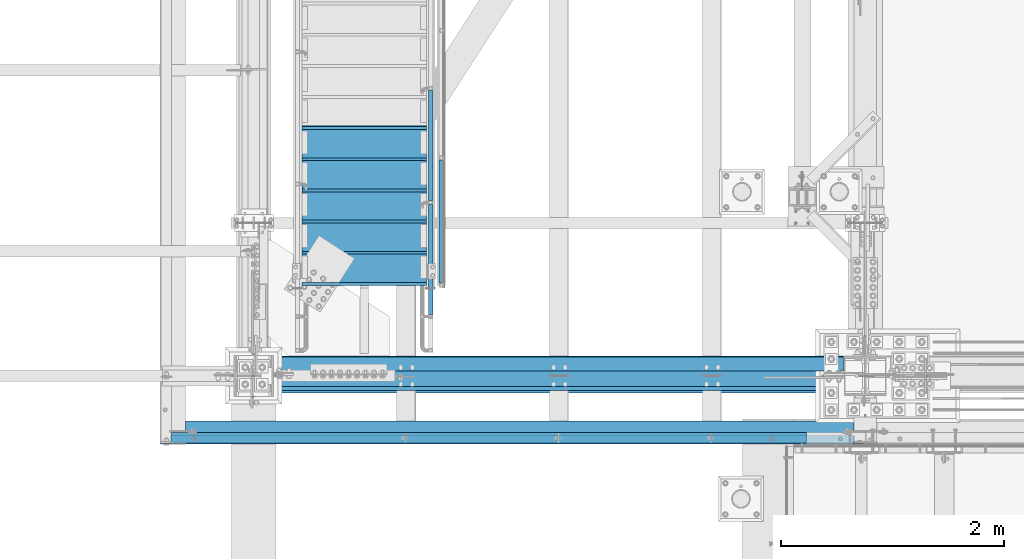
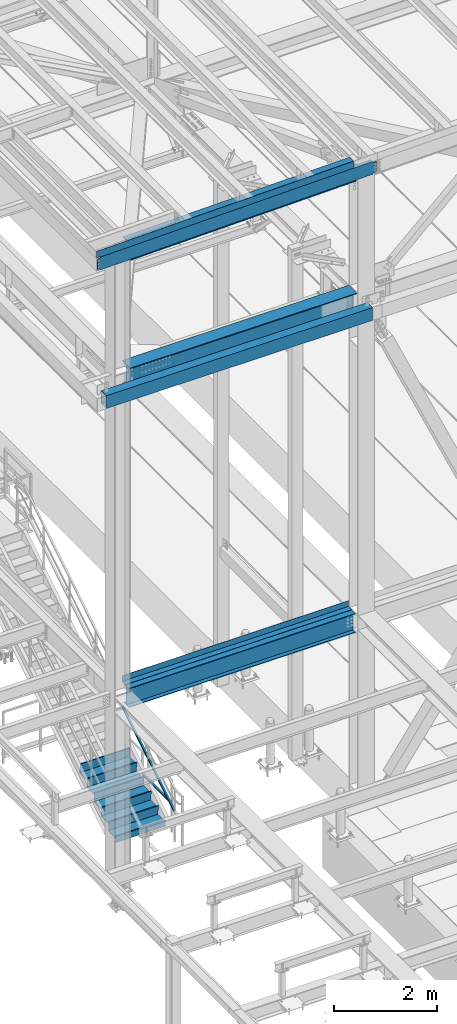
# One storey, part 1744 of 3843: 14 beams, 2 members, 8 elements without a shape of their own.
"""IFC2X3 building model written with IfcOpenShell, lengths in millimetres."""

from ifc_helpers import new_model, si_unit, frame, origin_with_axes, place, context, subcontext, project, spatial, faceted_brep, material, type_object, element, aggregate, save


model = new_model("IFC2X3")

# Units and contexts
model_context = context("Model", 3, precision=1e-05, world=origin_with_axes())
body_context = subcontext(model_context, "Body", "Model", "MODEL_VIEW")
ifc_project = project(units=[si_unit("LENGTHUNIT", "METRE", prefix="MILLI"), si_unit("AREAUNIT", "SQUARE_METRE"), si_unit("VOLUMEUNIT", "CUBIC_METRE"), si_unit("MASSUNIT", "GRAM", prefix="KILO"), si_unit("TIMEUNIT", "SECOND"), si_unit("PLANEANGLEUNIT", "RADIAN"), si_unit("SOLIDANGLEUNIT", "STERADIAN"), si_unit("THERMODYNAMICTEMPERATUREUNIT", "DEGREE_CELSIUS"), si_unit("LUMINOUSINTENSITYUNIT", "LUMEN")], contexts=[model_context])

# Site, building, storey
site_placement = place(None, origin_with_axes())
site = spatial("IfcSite", under=ifc_project, at=site_placement, CompositionType="ELEMENT")
building_placement = place(site_placement, origin_with_axes())
building = spatial("IfcBuilding", under=site, at=building_placement, Name="Undefined", CompositionType="ELEMENT")
storey_placement = place(building_placement, origin_with_axes())
storey = spatial("IfcBuildingStorey", under=building, at=storey_placement, Name="Undefined", CompositionType="ELEMENT", Elevation=0.0)

# Assembly, beam
assembly_1_placement = place(storey_placement, origin_with_axes())
assembly_1 = element("IfcElementAssembly", 1, at=assembly_1_placement, inside=storey, Name="RAIL", AssemblyPlace="NOTDEFINED", PredefinedType="RIGID_FRAME")
ifc_material_1 = material()
beam_type_1 = type_object("IfcBeamType", Name="HSS1-1/2X1-1/2X1/4", PredefinedType="NOTDEFINED")
beam_1_placement = place(assembly_1_placement, frame((38258.75, 26428.6999999811, 31013.4), z_axis=(0.0, 0.0, 1.0), x_axis=(0.0, 1.0, 0.0)))
beam_1 = element("IfcBeam", 2, at=beam_1_placement, type_object=beam_type_1, material=ifc_material_1, Name="RAIL", ObjectType="HSS1-1/2X1-1/2X1/4", context=body_context, shape_type="Brep", body=[
    faceted_brep([(1123.95, -19.0500000000029, 19.0499992350015), (1123.95, -19.0499992350015, -19.0499992350015), (1123.95, 19.0499992350015, -19.0499992350015), (1123.95, 19.0499992350015, 19.0499992350015), (1123.95, -12.6999993299978, 12.6999993300014), (1123.95, 12.6999993299978, 12.6999993300014), (1123.95, 12.6999993299978, -12.6999993300014), (1123.95, -12.6999993299978, -12.6999993300014), (19.0499992350015, 19.0499992350015, -19.0499992350015), (19.0499992350015, 19.0499992350015, 19.0499992350015), (19.0499992350015, -19.0499992350015, 19.0499992350015), (19.0499992350015, -19.0499992350015, -19.0499992350015), (19.0499992350015, 12.6999993299978, 12.6999993299978), (19.0499992350015, -12.6999993299978, 12.6999993299978), (19.0499992350015, -12.6999993299978, -12.6999993299978), (19.0499992350015, 12.6999993299978, -12.6999993299978)], [[[0, 1, 2, 3], [4, 5, 6, 7]], [[8, 9, 3, 2]], [[9, 10, 0, 3]], [[10, 11, 1, 0]], [[11, 8, 2, 1]], [[11, 10, 9, 8], [12, 13, 14, 15]], [[14, 13, 4, 7]], [[15, 14, 7, 6]], [[12, 15, 6, 5]], [[13, 12, 5, 4]]]),
])
aggregate(assembly_1, [beam_1])

# Assembly, members
assembly_2_placement = place(storey_placement, origin_with_axes())
assembly_2 = element("IfcElementAssembly", 3, at=assembly_2_placement, inside=storey, Name="RAIL", AssemblyPlace="NOTDEFINED", PredefinedType="RIGID_FRAME")
member_type = type_object("IfcMemberType", Name="HSS1-1/2X1-1/2X1/4", PredefinedType="NOTDEFINED")
member_1_placement = place(assembly_2_placement, frame((38163.4999999504, 27171.65, 31650.7090912731), z_axis=(0.0, -0.529007926750979, 0.848616882600523), x_axis=(0.0, 0.848616882600524, 0.529007926750978)))
member_1 = element("IfcMember", 4, at=member_1_placement, type_object=member_type, material=ifc_material_1, Name="RAIL", ObjectType="HSS1-1/2X1-1/2X1/4", context=body_context, shape_type="Brep", body=[
    faceted_brep([(1194.15206246817, -19.0499999811145, 19.0499992336445), (1170.40141407416, -19.0499992350015, -19.0499992362566), (1170.40141407416, 19.0499992350015, -19.0499992362566), (1194.15206246817, 19.0499992350015, 19.0499992336445), (1190.19362096973, -12.6999993299978, 12.6999993286627), (1190.19362096973, 12.6999993299978, 12.6999993286627), (1174.35985557328, 12.6999993299978, -12.6999993312675), (1174.35985557328, -12.6999993299978, -12.6999993312675), (10.5729683018217, 19.0499992350015, -19.0499992349742), (34.3236166958304, 19.0499992350015, 19.0499992349305), (34.3236166958304, -19.0500000222455, 19.0499992349305), (10.5729683018217, -19.0499992350015, -19.0499992349742), (30.3651751973375, -12.6999993299978, 12.6999993299451), (14.5314098008821, -12.6999993299978, -12.6999993299924), (14.5314098008821, 12.6999993299978, -12.6999993299924), (30.3651751973375, 12.6999993299978, 12.6999993299451)], [[[0, 1, 2, 3], [4, 5, 6, 7]], [[8, 9, 3, 2]], [[9, 10, 0, 3]], [[10, 11, 1, 0]], [[11, 8, 2, 1]], [[10, 9, 8, 11], [12, 13, 14, 15]], [[13, 12, 4, 7]], [[14, 13, 7, 6]], [[15, 14, 6, 5]], [[12, 15, 5, 4]]]),
])
member_2_placement = place(assembly_2_placement, frame((38163.4999999557, 26149.3, 31013.4000000026), z_axis=(0.0, -0.529007926750979, 0.848616882600523), x_axis=(0.0, 0.848616882600524, 0.529007926750978)))
member_2 = element("IfcMember", 5, at=member_2_placement, type_object=member_type, material=ifc_material_1, Name="RAIL", ObjectType="HSS1-1/2X1-1/2X1/4", context=body_context, shape_type="Brep", body=[
    faceted_brep([(1194.15206246817, -19.0499999811145, 19.0499992336445), (1170.40141407416, -19.0499992350015, -19.0499992362566), (1170.40141407416, 19.0499992350015, -19.0499992362566), (1194.15206246817, 19.0499992350015, 19.0499992336445), (1190.19362096973, -12.6999993299978, 12.6999993286627), (1190.19362096973, 12.6999993299978, 12.6999993286627), (1174.35985557328, 12.6999993299978, -12.6999993312675), (1174.35985557328, -12.6999993299978, -12.6999993312675), (10.5729683018217, 19.0499992350015, -19.0499992349742), (34.3236166958304, 19.0499992350015, 19.0499992349305), (34.3236166958304, -19.0500000222455, 19.0499992349305), (10.5729683018217, -19.0499992350015, -19.0499992349742), (30.3651751973375, -12.6999993299978, 12.6999993299451), (14.5314098008821, -12.6999993299978, -12.6999993299924), (14.5314098008821, 12.6999993299978, -12.6999993299924), (30.3651751973375, 12.6999993299978, 12.6999993299451)], [[[0, 1, 2, 3], [4, 5, 6, 7]], [[8, 9, 3, 2]], [[9, 10, 0, 3]], [[10, 11, 1, 0]], [[11, 8, 2, 1]], [[10, 9, 8, 11], [12, 13, 14, 15]], [[13, 12, 4, 7]], [[14, 13, 7, 6]], [[15, 14, 6, 5]], [[12, 15, 5, 4]]]),
])
aggregate(assembly_2, [member_1, member_2])

# Assembly, beams
assembly_3_placement = place(storey_placement, origin_with_axes())
assembly_3 = element("IfcElementAssembly", 6, at=assembly_3_placement, inside=storey, Name="BEAM", AssemblyPlace="NOTDEFINED", PredefinedType="RIGID_FRAME")
ifc_material_2 = material(Name="STEEL/A572-50")
beam_type_2 = type_object("IfcBeamType", Name="C12X20.7", PredefinedType="NOTDEFINED")
beam_2_placement = place(assembly_3_placement, frame((35741.0235796553, 25044.4000000811, 45559.4950698048), z_axis=(0.0211520550054438, 0.0, -0.999776270257025), x_axis=(0.999776270257024, 0.0, 0.0211520550054619)))
beam_2 = element("IfcBeam", 7, at=beam_2_placement, type_object=beam_type_2, material=ifc_material_2, Name="BEAM", ObjectType="C12X20.7", context=body_context, shape_type="Brep", body=[
    faceted_brep([(20.6374999136679, 30.1625000000058, -126.999999999352), (20.6374999136679, 38.1000000000058, -126.999999999352), (77.7875001037028, 38.1000000000058, -126.999999999302), (77.7875001037028, 30.1625000000058, -126.999999999302), (82.6475796217346, 38.1000000000058, -127.966729921885), (82.6475796217346, 30.1625000000058, -127.966729921885), (86.7677560898665, 38.1000000000058, -130.719743822337), (86.7677560898665, 30.1625000000058, -130.719743822337), (89.5207699903331, 38.1000000000058, -134.839920290469), (89.5207699903403, 30.1625000000058, -134.674927499684), (90.4874999129242, 1.14757858682424e-06, -139.699999808494), (90.4874999129242, 38.1000000000058, -139.699999808494), (90.4874999129315, 38.1000000000058, -152.399999999659), (90.4874999129388, -38.1000000000058, -152.39999980729), (90.4874999129315, -38.1000000000058, -146.047459999667), (6221.00785836641, -38.1000000000058, 146.047460006012), (6221.0078583664, -38.1000000000058, 152.400000005997), (90.4874999126405, -38.1000000000058, 152.39999980975), (90.4874999126478, -38.1000000000058, 146.047459999863), (6221.0078583664, 38.1000000000058, 152.400000005997), (90.4874999126478, 38.1000000000058, 152.399999999849), (77.7875001034699, 30.1625000000058, 126.999999999338), (77.7875001034699, 38.1000000000058, 126.999999999338), (20.6374999136751, 38.1000000000058, 126.999999999272), (20.6374999136751, 30.1625000000058, 126.999999999272), (82.6475796214872, 30.1625000000058, 127.966729921922), (82.6475796214872, 38.1000000000058, 127.966729921922), (86.7677560896191, 30.1625000000058, 130.719743822396), (86.7677560896191, 38.1000000000058, 130.719743822396), (89.5207699900784, 30.1625000000058, 134.674927499873), (89.5207699900784, 38.1000000000058, 134.839920290535), (90.487499912655, 1.14834983833134e-06, 139.699999808552), (90.487499912655, 38.1000000000058, 139.699999808552), (6221.974588289, 30.1625000000058, 134.674927506036), (6221.00785836641, 8.03440343588591e-07, 139.699999872166), (6221.00785836641, 38.1000000000058, 139.699999872166), (6221.974588289, 38.1000000000058, 134.839920354148), (6224.72760218947, 30.1625000000058, 130.719743886017), (6224.72760218947, 38.1000000000058, 130.719743886017), (6228.8477786576, 30.1625000000058, 127.966729985557), (6228.8477786576, 38.1000000000058, 127.966729985557), (6233.70785817563, 30.1625000000058, 127.000000062973), (6233.70785817563, 38.1000000000058, 127.000000062973), (6303.55742588337, 30.1625000000058, 127.000000063053), (6303.55737560392, 38.1000000000058, 127.000000063039), (6303.55742572207, 30.1624999999985, 116.300000027353), (6303.55742595262, 30.1624999999985, -114.299999971117), (6303.55742562941, 30.1625000000058, -126.999999935717), (6303.55737534998, 38.1000000000058, -126.999999935724), (6233.70785817589, 30.1625000000058, -126.999999935797), (6233.70785817589, 38.1000000000058, -126.999999935797), (6228.84777865787, 30.1625000000058, -127.966729858381), (6228.84777865787, 38.1000000000058, -127.966729858381), (6224.72760218974, 30.1625000000058, -130.719743758855), (6224.72760218974, 38.1000000000058, -130.719743758855), (6221.97458828928, 30.1625000000058, -134.674927493536), (6221.97458828928, 38.1000000000058, -134.839920226987), (6221.0078583667, 1.4916731743142e-06, -139.699999745018), (6221.0078583667, 38.1000000000058, -139.699999745018), (6221.00785836671, -38.1000000000058, -146.047459993511), (6221.00785836672, -38.1000000000058, -152.399999993504), (6221.00785836672, 38.1000000000058, -152.399999993504), (20.6374999295222, 30.1625000000004, -114.29999996836), (20.6375001600682, 30.1625000000004, 116.300000028175)], [[[0, 1, 2, 3]], [[3, 2, 4, 5]], [[5, 4, 6, 7]], [[7, 6, 8, 9]], [[10, 11, 12, 13, 14]], [[9, 8, 11, 10]], [[15, 16, 17, 18]], [[16, 19, 20, 17]], [[21, 22, 23, 24]], [[25, 26, 22, 21]], [[27, 28, 26, 25]], [[29, 30, 28, 27]], [[31, 32, 30, 29]], [[17, 20, 32, 31, 18]], [[29, 33, 34, 15, 18, 31]], [[16, 15, 34, 35, 19]], [[33, 36, 35, 34]], [[37, 38, 36, 33]], [[39, 40, 38, 37]], [[41, 42, 40, 39]], [[43, 44, 42, 41]], [[44, 43, 45, 46, 47, 48]], [[47, 49, 50, 48]], [[51, 52, 50, 49]], [[53, 54, 52, 51]], [[55, 56, 54, 53]], [[57, 58, 56, 55]], [[59, 60, 61, 58, 57]], [[60, 59, 14, 13]], [[61, 60, 13, 12]], [[6, 4, 2, 1, 23, 22, 26, 28, 30, 32, 20, 19, 35, 36, 38, 40, 42, 44, 48, 50, 52, 54, 56, 58, 61, 12, 11, 8]], [[62, 63, 24, 23, 1, 0]], [[55, 53, 51, 49, 47, 46, 45, 43, 41, 39, 37, 33, 29, 27, 25, 21, 24, 63, 62, 0, 3, 5, 7, 9]], [[59, 57, 55, 9, 10, 14]]]),
])
ifc_material_3 = material(Name="STEEL/A36")
beam_type_3 = type_object("IfcBeamType", PredefinedType="NOTDEFINED")
beam_3_placement = place(assembly_3_placement, frame((38639.0335905506, 25107.8999997032, 45776.4175910696), z_axis=(0.999776270257024, 0.0, 0.0211520550054619), x_axis=(0.0, -1.0, 0.0)))
beam_3 = element("IfcBeam", 8, at=beam_3_placement, type_object=beam_type_3, material=ifc_material_3, Name="BENT_PLATE", context=body_context, shape_type="Brep", body=[
    faceted_brep([(101.599999703314, -3.17499999719439, -2800.35000762786), (95.2499990730139, -3.1749999972817, -2800.35000762787), (1.01863406598568e-10, -3.17499999720167, -2800.35000762786), (1.0550138540566e-10, 3.17500000279688, -2800.35000762787), (101.599999047881, 3.17500000270957, -2800.35000762787), (101.599999073012, -3.1749999970998, -2895.59999999531), (95.2499990734032, -3.17499999718711, -2895.5999999953), (95.2499997009763, -161.925000941941, 2895.59999999518), (95.2499997016348, -161.92500093647, -2895.59999999545), (101.599999701637, -161.925000911338, -2895.59999999544), (101.599999700979, -161.925000916817, 2895.59999999518), (101.599999047587, 3.17499999699066, 2895.59999999533), (-2.11002770811319e-10, 3.17499999707798, 2895.59999999533), (-2.18278728425503e-10, -3.17500000290602, 2895.59999999533), (95.2499990727156, -3.17500000299333, 2895.59999999533)], [[[0, 1, 2, 3, 4]], [[5, 6, 1, 0]], [[7, 8, 9, 10]], [[11, 12, 13, 14, 7, 10]], [[12, 11, 4, 3]], [[13, 12, 3, 2]], [[14, 13, 2, 1]], [[8, 7, 14, 1, 6]], [[9, 8, 6, 5]], [[11, 10, 9, 5, 0, 4]]]),
])
aggregate(assembly_3, [beam_2, beam_3])

# Assembly, beam
assembly_4_placement = place(storey_placement, origin_with_axes())
assembly_4 = element("IfcElementAssembly", 9, at=assembly_4_placement, inside=storey, Name="BEAM", AssemblyPlace="NOTDEFINED", PredefinedType="RIGID_FRAME")
ifc_material_4 = material(Name="STEEL/A992")
beam_type_4 = type_object("IfcBeamType", Name="W21X101", PredefinedType="NOTDEFINED")
beam_4_placement = place(assembly_4_placement, frame((36576.0, 25615.9, 42197.3375), z_axis=(0.0, 0.0, 1.0), x_axis=(1.0, 0.0, 0.0)))
beam_4 = element("IfcBeam", 10, at=beam_4_placement, type_object=beam_type_4, material=ifc_material_4, Name="BEAM", ObjectType="W21X101", context=body_context, shape_type="Brep", body=[
    faceted_brep([(190.5, 155.575000000001, -250.824999999997), (190.5, 6.34999999999854, -250.824999999997), (5289.55, 6.34999999999854, -250.824999999997), (5289.55, 147.637500000004, -250.824999999997), (5289.55, 155.575000000001, -250.824999999997), (190.5, 6.34999999999854, 250.824999999997), (5289.55, 6.34999999999854, 250.824999999997), (5289.55, 6.34999999999854, 215.052499999998), (5289.55, 6.34999999999854, -180.127499999995), (190.5, 155.575000000001, 250.824999999997), (5289.55, 155.575000000001, 250.824999999997), (5289.55, 147.637500000004, 250.824999999997), (190.5, 155.575000000001, 271.462500000001), (5289.55, 155.575000000001, 271.462500000001), (190.5, -155.575000000001, 271.462500000001), (5289.55, -155.575000000001, 271.462500000001), (5289.55, -147.637499999997, 271.462500000001), (5289.55, 147.637500000004, 271.462500000001), (190.5, -155.575000000001, 250.824999999997), (5289.55, -155.575000000001, 250.824999999997), (190.5, -6.34999999999854, 250.824999999997), (5289.55, -6.34999999999854, 250.824999999997), (5289.55, -147.637499999997, 250.824999999997), (190.5, -6.34999999999854, -250.824999999997), (5289.55, -6.34999999999854, -250.824999999997), (190.5, -155.575000000001, -250.824999999997), (5289.55, -155.575000000001, -250.824999999997), (5289.55, -147.637499999997, -250.824999999997), (190.5, -155.575000000001, -271.462500000001), (5289.55, -155.575000000001, -271.462500000001), (190.5, 155.575000000001, -271.462500000001), (5289.55, 155.575000000001, -271.462500000001), (5289.55, 147.637500000004, -271.462500000001), (5289.55, -147.637499999997, -271.462500000001)], [[[0, 1, 2, 3, 4]], [[1, 5, 6, 7, 8, 2]], [[5, 9, 10, 11, 6]], [[9, 12, 13, 10]], [[12, 14, 15, 16, 17, 13]], [[14, 18, 19, 15]], [[18, 20, 21, 22, 19]], [[20, 23, 24, 21]], [[23, 25, 26, 27, 24]], [[25, 28, 29, 26]], [[28, 30, 31, 32, 33, 29]], [[3, 2, 8, 7, 6, 11, 10, 13, 17, 16, 15, 19, 22, 21, 24, 27, 26, 29, 33, 32, 31, 4]], [[30, 0, 4, 31]], [[28, 25, 23, 20, 18, 14, 12, 9, 5, 1, 0, 30]]]),
])
aggregate(assembly_4, [beam_4])

# Assembly, beams
assembly_5_placement = place(storey_placement, origin_with_axes())
assembly_5 = element("IfcElementAssembly", 11, at=assembly_5_placement, inside=storey, Name="STAIR", AssemblyPlace="NOTDEFINED", PredefinedType="RIGID_FRAME")
ifc_material_5 = material(Name="STEEL/ASTM A1011")
beam_type_5 = type_object("IfcBeamType", PredefinedType="NOTDEFINED")
beam_5_placement = place(assembly_5_placement, frame((37566.5999999524, 27851.0999999812, 31523.4410714342), z_axis=(1.0, 0.0, 0.0), x_axis=(0.0, -1.0, 0.0)))
beam_5 = element("IfcBeam", 12, at=beam_5_placement, type_object=beam_type_5, material=ifc_material_5, Name="TREAD", context=body_context, shape_type="Brep", body=[
    faceted_brep([(0.0, -1.58750000000146, -558.799999999999), (0.0, -1.58750000000146, 558.799999999999), (0.0, 1.58750000000146, 558.799999999999), (0.0, 1.58750000000146, -558.799999999999), (21.7283948539116, 1.58750000000146, 558.800000000003), (21.7283948539116, 1.58750000000146, -558.800000000003), (25.3999999999942, -1.58750000000146, -558.799999999999), (25.3999999999942, -1.58750000000146, 558.799999999999), (-11.0799384794227, 226.55892857143, 558.800000000003), (-11.0799384794227, 226.55892857143, -558.800000000003), (-7.40833333332557, 223.383928571428, -558.800000000003), (-7.40833333332557, 223.383928571428, 558.800000000003), (293.720061520566, 226.55892857143, 558.800000000003), (293.720061520566, 226.55892857143, -558.800000000003), (290.974498041134, 223.383928571428, -558.800000000003), (290.974498041134, 223.383928571428, 558.800000000003), (299.614357882056, 186.140896378427, 558.800000000003), (299.614357882056, 186.140896378427, -558.800000000003), (296.472590667174, 185.682721992918, 558.800000000003), (296.472590667174, 185.682721992918, -558.800000000003)], [[[0, 1, 2, 3]], [[3, 2, 4, 5]], [[1, 0, 6, 7]], [[5, 4, 8, 9]], [[7, 6, 10, 11]], [[9, 8, 12, 13]], [[11, 10, 14, 15]], [[13, 12, 16, 17]], [[12, 8, 4, 2, 1, 7, 11, 15, 18, 16]], [[15, 14, 19, 18]], [[14, 10, 6, 0, 3, 5, 9, 13, 17, 19]], [[18, 19, 17, 16]]]),
])
beam_6_placement = place(assembly_5_placement, frame((37566.5999999524, 27571.6999999811, 31349.2696428628), z_axis=(1.0, 0.0, 0.0), x_axis=(0.0, -1.0, 0.0)))
beam_6 = element("IfcBeam", 13, at=beam_6_placement, type_object=beam_type_5, material=ifc_material_5, Name="TREAD", context=body_context, shape_type="Brep", body=[
    faceted_brep([(0.0, -1.58750000000146, -558.799999999999), (0.0, -1.58750000000146, 558.799999999999), (0.0, 1.58750000000146, 558.799999999999), (0.0, 1.58750000000146, -558.799999999999), (21.7283948539116, 1.58750000000146, 558.800000000003), (21.7283948539116, 1.58750000000146, -558.800000000003), (25.3999999999942, -1.58750000000146, -558.799999999999), (25.3999999999942, -1.58750000000146, 558.799999999999), (-11.0799384794227, 226.55892857143, 558.800000000003), (-11.0799384794227, 226.55892857143, -558.800000000003), (-7.40833333332557, 223.383928571428, -558.800000000003), (-7.40833333332557, 223.383928571428, 558.800000000003), (293.720061520566, 226.55892857143, 558.800000000003), (293.720061520566, 226.55892857143, -558.800000000003), (290.974498041134, 223.383928571428, -558.800000000003), (290.974498041134, 223.383928571428, 558.800000000003), (299.614357882056, 186.140896378427, 558.800000000003), (299.614357882056, 186.140896378427, -558.800000000003), (296.472590667174, 185.682721992918, 558.800000000003), (296.472590667174, 185.682721992918, -558.800000000003)], [[[0, 1, 2, 3]], [[3, 2, 4, 5]], [[1, 0, 6, 7]], [[5, 4, 8, 9]], [[7, 6, 10, 11]], [[9, 8, 12, 13]], [[11, 10, 14, 15]], [[13, 12, 16, 17]], [[12, 8, 4, 2, 1, 7, 11, 15, 18, 16]], [[15, 14, 19, 18]], [[14, 10, 6, 0, 3, 5, 9, 13, 17, 19]], [[18, 19, 17, 16]]]),
])
beam_7_placement = place(assembly_5_placement, frame((37566.5999999524, 27292.2999999811, 31175.0982142914), z_axis=(1.0, 0.0, 0.0), x_axis=(0.0, -1.0, 0.0)))
beam_7 = element("IfcBeam", 14, at=beam_7_placement, type_object=beam_type_5, material=ifc_material_5, Name="TREAD", context=body_context, shape_type="Brep", body=[
    faceted_brep([(0.0, -1.58750000000146, -558.799999999999), (0.0, -1.58750000000146, 558.799999999999), (0.0, 1.58750000000146, 558.799999999999), (0.0, 1.58750000000146, -558.799999999999), (21.7283948539116, 1.58750000000146, 558.800000000003), (21.7283948539116, 1.58750000000146, -558.800000000003), (25.3999999999942, -1.58750000000146, -558.799999999999), (25.3999999999942, -1.58750000000146, 558.799999999999), (-11.0799384794227, 226.55892857143, 558.800000000003), (-11.0799384794227, 226.55892857143, -558.800000000003), (-7.40833333332557, 223.383928571428, -558.800000000003), (-7.40833333332557, 223.383928571428, 558.800000000003), (293.720061520566, 226.55892857143, 558.800000000003), (293.720061520566, 226.55892857143, -558.800000000003), (290.974498041134, 223.383928571428, -558.800000000003), (290.974498041134, 223.383928571428, 558.800000000003), (299.614357882056, 186.140896378427, 558.800000000003), (299.614357882056, 186.140896378427, -558.800000000003), (296.472590667174, 185.682721992918, 558.800000000003), (296.472590667174, 185.682721992918, -558.800000000003)], [[[0, 1, 2, 3]], [[3, 2, 4, 5]], [[1, 0, 6, 7]], [[5, 4, 8, 9]], [[7, 6, 10, 11]], [[9, 8, 12, 13]], [[11, 10, 14, 15]], [[13, 12, 16, 17]], [[12, 8, 4, 2, 1, 7, 11, 15, 18, 16]], [[15, 14, 19, 18]], [[14, 10, 6, 0, 3, 5, 9, 13, 17, 19]], [[18, 19, 17, 16]]]),
])
beam_8_placement = place(assembly_5_placement, frame((37566.5999999524, 27012.8999999811, 31000.92678572), z_axis=(1.0, 0.0, 0.0), x_axis=(0.0, -1.0, 0.0)))
beam_8 = element("IfcBeam", 15, at=beam_8_placement, type_object=beam_type_5, material=ifc_material_5, Name="TREAD", context=body_context, shape_type="Brep", body=[
    faceted_brep([(0.0, -1.58750000000146, -558.799999999999), (0.0, -1.58750000000146, 558.799999999999), (0.0, 1.58750000000146, 558.799999999999), (0.0, 1.58750000000146, -558.799999999999), (21.7283948539116, 1.58750000000146, 558.800000000003), (21.7283948539116, 1.58750000000146, -558.800000000003), (25.3999999999942, -1.58750000000146, -558.799999999999), (25.3999999999942, -1.58750000000146, 558.799999999999), (-11.0799384794227, 226.55892857143, 558.800000000003), (-11.0799384794227, 226.55892857143, -558.800000000003), (-7.40833333332557, 223.383928571428, -558.800000000003), (-7.40833333332557, 223.383928571428, 558.800000000003), (293.720061520566, 226.55892857143, 558.800000000003), (293.720061520566, 226.55892857143, -558.800000000003), (290.974498041134, 223.383928571428, -558.800000000003), (290.974498041134, 223.383928571428, 558.800000000003), (299.614357882056, 186.140896378427, 558.800000000003), (299.614357882056, 186.140896378427, -558.800000000003), (296.472590667174, 185.682721992918, 558.800000000003), (296.472590667174, 185.682721992918, -558.800000000003)], [[[0, 1, 2, 3]], [[3, 2, 4, 5]], [[1, 0, 6, 7]], [[5, 4, 8, 9]], [[7, 6, 10, 11]], [[9, 8, 12, 13]], [[11, 10, 14, 15]], [[13, 12, 16, 17]], [[12, 8, 4, 2, 1, 7, 11, 15, 18, 16]], [[15, 14, 19, 18]], [[14, 10, 6, 0, 3, 5, 9, 13, 17, 19]], [[18, 19, 17, 16]]]),
])
beam_9_placement = place(assembly_5_placement, frame((37566.5999999524, 26733.4999999811, 30826.7553571485), z_axis=(1.0, 0.0, 0.0), x_axis=(0.0, -1.0, 0.0)))
beam_9 = element("IfcBeam", 16, at=beam_9_placement, type_object=beam_type_5, material=ifc_material_5, Name="TREAD", context=body_context, shape_type="Brep", body=[
    faceted_brep([(0.0, -1.58750000000146, -558.799999999999), (0.0, -1.58750000000146, 558.799999999999), (0.0, 1.58750000000146, 558.799999999999), (0.0, 1.58750000000146, -558.799999999999), (21.7283948539116, 1.58750000000146, 558.800000000003), (21.7283948539116, 1.58750000000146, -558.800000000003), (25.3999999999942, -1.58750000000146, -558.799999999999), (25.3999999999942, -1.58750000000146, 558.799999999999), (-11.0799384794227, 226.55892857143, 558.800000000003), (-11.0799384794227, 226.55892857143, -558.800000000003), (-7.40833333332557, 223.383928571428, -558.800000000003), (-7.40833333332557, 223.383928571428, 558.800000000003), (293.720061520566, 226.55892857143, 558.800000000003), (293.720061520566, 226.55892857143, -558.800000000003), (290.974498041134, 223.383928571428, -558.800000000003), (290.974498041134, 223.383928571428, 558.800000000003), (299.614357882056, 186.140896378427, 558.800000000003), (299.614357882056, 186.140896378427, -558.800000000003), (296.472590667174, 185.682721992918, 558.800000000003), (296.472590667174, 185.682721992918, -558.800000000003)], [[[0, 1, 2, 3]], [[3, 2, 4, 5]], [[1, 0, 6, 7]], [[5, 4, 8, 9]], [[7, 6, 10, 11]], [[9, 8, 12, 13]], [[11, 10, 14, 15]], [[13, 12, 16, 17]], [[12, 8, 4, 2, 1, 7, 11, 15, 18, 16]], [[15, 14, 19, 18]], [[14, 10, 6, 0, 3, 5, 9, 13, 17, 19]], [[18, 19, 17, 16]]]),
])
beam_type_6 = type_object("IfcBeamType", PredefinedType="NOTDEFINED")
beam_10_placement = place(assembly_5_placement, frame((37566.5999999524, 26454.0999999811, 30652.5839285771), z_axis=(1.0, 0.0, 0.0), x_axis=(0.0, -1.0, 0.0)))
beam_10 = element("IfcBeam", 17, at=beam_10_placement, type_object=beam_type_6, material=ifc_material_5, Name="TREAD", context=body_context, shape_type="Brep", body=[
    faceted_brep([(0.0, -1.58750000000146, -558.799999999999), (0.0, -1.58750000000146, 558.799999999999), (0.0, 1.58750000000146, 558.799999999999), (0.0, 1.58750000000146, -558.799999999999), (21.7283948539116, 1.58750000000146, 558.800000000003), (21.7283948539116, 1.58750000000146, -558.800000000003), (25.3999999999942, -1.58750000000146, -558.799999999999), (25.3999999999942, -1.58750000000146, 558.799999999999), (-1.81885054821032, 163.054325614496, 558.800000000003), (-1.81885054821032, 163.054325614496, -558.800000000003), (1.32291666666424, 163.512499999997, 558.800000000003), (1.32291666666424, 163.512499999997, -558.800000000003)], [[[0, 1, 2, 3]], [[3, 2, 4, 5]], [[1, 0, 6, 7]], [[5, 4, 8, 9]], [[4, 2, 1, 7, 10, 8]], [[7, 6, 11, 10]], [[6, 0, 3, 5, 9, 11]], [[10, 11, 9, 8]]]),
])
aggregate(assembly_5, [beam_5, beam_6, beam_7, beam_8, beam_9, beam_10])

# Assembly, beam
assembly_6_placement = place(storey_placement, origin_with_axes())
assembly_6 = element("IfcElementAssembly", 18, at=assembly_6_placement, inside=storey, Name="GIRT", AssemblyPlace="NOTDEFINED", PredefinedType="RIGID_FRAME")
ifc_material_6 = material()
beam_type_7 = type_object("IfcBeamType", Name="HSS12X8X3/8", PredefinedType="NOTDEFINED")
beam_11_placement = place(assembly_6_placement, frame((35963.2250000001, 25107.9, 42214.8000000001), z_axis=(0.0, 0.0, 1.0), x_axis=(1.0, 0.0, 0.0)))
beam_11 = element("IfcBeam", 19, at=beam_11_placement, type_object=beam_type_7, material=ifc_material_6, Name="GIRT", ObjectType="HSS12X8X3/8", context=body_context, shape_type="Brep", body=[
    faceted_brep([(5995.9875, 101.599999999999, -152.400000000001), (5995.9875, -101.599999999999, -152.400000000001), (1.58750000000146, -101.599999999999, -152.400000000001), (1.58750000000146, 101.599999999999, -152.400000000001), (5995.9875, 101.599999999999, 152.400000000001), (1.58750000000146, 101.599999999999, 152.400000000001), (5995.9875, -101.599999999999, 152.400000000001), (1.58750000000146, -101.599999999999, 152.400000000001), (5995.9875, 92.0750000000007, -142.875), (5995.9875, -92.0750000000007, -142.875), (5995.9875, -92.0750000000007, 142.875), (5995.9875, 92.0750000000007, 142.875), (1.58750000000146, -92.0750000000007, 142.875), (1.58750000000146, 92.0750000000007, 142.875), (1.58750000000146, 92.0750000000007, -142.875), (1.58750000000146, -92.0750000000007, -142.875)], [[[0, 1, 2, 3]], [[4, 0, 3, 5]], [[6, 4, 5, 7]], [[1, 6, 7, 2]], [[0, 4, 6, 1], [8, 9, 10, 11]], [[11, 10, 12, 13]], [[8, 11, 13, 14]], [[9, 8, 14, 15]], [[10, 9, 15, 12]], [[3, 2, 7, 5], [14, 13, 12, 15]]]),
])
aggregate(assembly_6, [beam_11])

assembly_7_placement = place(storey_placement, origin_with_axes())
assembly_7 = element("IfcElementAssembly", 20, at=assembly_7_placement, inside=storey, Name="BEAM", AssemblyPlace="NOTDEFINED", PredefinedType="RIGID_FRAME")
beam_type_8 = type_object("IfcBeamType", PredefinedType="NOTDEFINED")
beam_12_placement = place(assembly_7_placement, frame((39316.025, 25660.35, 34813.875), z_axis=(-1.0, 0.0, 0.0), x_axis=(0.0, 1.0, 0.0)))
beam_12 = element("IfcBeam", 21, at=beam_12_placement, type_object=beam_type_8, material=ifc_material_3, Name="BENT_PLATE", context=body_context, shape_type="Brep", body=[
    faceted_brep([(0.0, -3.17500000000291, -2549.525), (0.0, -3.17500000000291, 2549.525), (0.0, 3.17500000000291, 2549.525), (0.0, 3.17500000000291, -2549.525), (133.349999999995, 3.17500000000291, 2549.525), (133.349999999995, 3.17500000000291, -2549.525), (126.999999999996, -3.17500000000291, -2549.525), (126.999999999996, -3.17500000000291, 2549.525), (133.349999999995, -136.524999999994, 2549.525), (133.349999999995, -136.524999999994, -2549.525), (126.999999999996, -136.524999999994, 2549.525), (126.999999999996, -136.524999999994, -2549.525)], [[[0, 1, 2, 3]], [[3, 2, 4, 5]], [[1, 0, 6, 7]], [[5, 4, 8, 9]], [[4, 2, 1, 7, 10, 8]], [[7, 6, 11, 10]], [[6, 0, 3, 5, 9, 11]], [[10, 11, 9, 8]]]),
])

assembly_8_placement = place(storey_placement, origin_with_axes())
assembly_8 = element("IfcElementAssembly", 22, at=assembly_8_placement, inside=storey, Name="BEAM", AssemblyPlace="NOTDEFINED", PredefinedType="RIGID_FRAME")
beam_type_9 = type_object("IfcBeamType", Name="W16X67", PredefinedType="NOTDEFINED")
beam_13_placement = place(assembly_8_placement, frame((36580.3988432745, 25615.9, 45210.4590275866), z_axis=(-0.0211520980073474, 0.0, 0.999776269347241), x_axis=(0.999776270257024, 0.0, 0.0211520550054619)))
beam_13 = element("IfcBeam", 23, at=beam_13_placement, type_object=beam_type_9, material=ifc_material_4, Name="BEAM", ObjectType="W16X67", context=body_context, shape_type="Brep", body=[
    faceted_brep([(181.742975470595, -130.174999999999, -207.962499999499), (181.742975470595, 130.174999999999, -207.962499999499), (5281.93404407822, 130.174999999999, -207.962499994363), (5281.93404407822, -130.174999999999, -207.962499994363), (182.112426639622, -130.174999999999, -190.499999999527), (182.112426639622, -4.76250000000073, -190.499999999527), (190.173179417936, -4.76250000000073, 190.499999999862), (190.173179417936, -130.174999999999, 190.499999999862), (190.542630586948, -130.174999999999, 207.962499999841), (190.542630586948, 130.174999999999, 207.962499999841), (190.173179417936, 130.174999999999, 190.499999999862), (190.173179417936, 4.76250000000073, 190.499999999862), (182.112426639622, 4.76250000000073, -190.499999999527), (182.112426639622, 130.174999999999, -190.499999999527), (5282.30349524722, -130.174999999999, -190.499999994383), (5282.30349524722, -4.76250000000073, -190.499999994383), (5290.36424802549, -4.76250000000073, 190.500000005006), (5290.36424802549, -130.174999999999, 190.500000005006), (5290.7336991945, -130.174999999999, 207.962500004978), (5290.7336991945, 130.174999999999, 207.962500004978), (5290.36424802549, 130.174999999999, 190.500000005006), (5290.36424802549, 4.76250000000073, 190.500000005006), (5289.78924910998, 4.76250000000073, 163.322068509886), (5283.04215288762, 4.76250000000073, -155.586565885467), (5282.30349524722, 4.76250000000073, -190.499999994383), (5282.30349524722, 130.174999999999, -190.499999994383)], [[[0, 1, 2, 3]], [[0, 4, 5, 6, 7, 8, 9, 10, 11, 12, 13, 1]], [[5, 4, 14, 15]], [[6, 5, 15, 16]], [[7, 6, 16, 17]], [[8, 7, 17, 18]], [[9, 8, 18, 19]], [[10, 9, 19, 20]], [[11, 10, 20, 21]], [[12, 11, 21, 22, 23, 24]], [[13, 12, 24, 25]], [[1, 13, 25, 2]], [[24, 23, 22, 21, 20, 19, 18, 17, 16, 15, 14, 3, 2, 25]], [[4, 0, 3, 14]]]),
])
aggregate(assembly_8, [beam_13])

# Beam
beam_type_10 = type_object("IfcBeamType", Name="W18X50", PredefinedType="NOTDEFINED")
beam_14_placement = place(assembly_7_placement, frame((36576.0, 25615.9, 34582.1), z_axis=(0.0, 0.0, 1.0), x_axis=(1.0, 0.0, 0.0)))
beam_14 = element("IfcBeam", 24, at=beam_14_placement, type_object=beam_type_10, material=ifc_material_4, Name="BEAM", ObjectType="W18X50", context=body_context, shape_type="Brep", body=[
    faceted_brep([(190.5, 95.25, -228.599999999999), (190.5, 95.25, -214.3125), (5289.55, 95.25, -214.3125), (5289.55, 95.25, -228.599999999999), (190.5, 4.76250000000073, -214.3125), (5289.55, 4.76250000000073, -214.3125), (190.5, 4.76250000000073, 214.3125), (5289.55, 4.76250000000073, 214.3125), (190.5, 95.25, 214.3125), (5289.55, 95.25, 214.3125), (190.5, 95.25, 228.599999999999), (5289.55, 95.25, 228.599999999999), (190.5, -95.25, 228.599999999999), (5289.55, -95.25, 228.599999999999), (190.5, -95.25, 214.3125), (5289.55, -95.25, 214.3125), (190.5, -4.76250000000073, 214.3125), (5289.55, -4.76250000000073, 214.3125), (190.5, -4.76250000000073, -214.3125), (5289.55, -4.76250000000073, -214.3125), (190.5, -95.25, -214.3125), (5289.55, -95.25, -214.3125), (190.5, -95.25, -228.599999999999), (5289.55, -95.25, -228.599999999999)], [[[0, 1, 2, 3]], [[1, 4, 5, 2]], [[4, 6, 7, 5]], [[6, 8, 9, 7]], [[8, 10, 11, 9]], [[10, 12, 13, 11]], [[12, 14, 15, 13]], [[14, 16, 17, 15]], [[16, 18, 19, 17]], [[18, 20, 21, 19]], [[20, 22, 23, 21]], [[22, 0, 3, 23]], [[5, 7, 9, 11, 13, 15, 17, 19, 21, 23, 3, 2]], [[22, 20, 18, 16, 14, 12, 10, 8, 6, 4, 1, 0]]]),
])

aggregate(assembly_7, [beam_12, beam_14])

save(model, "model.ifc")
